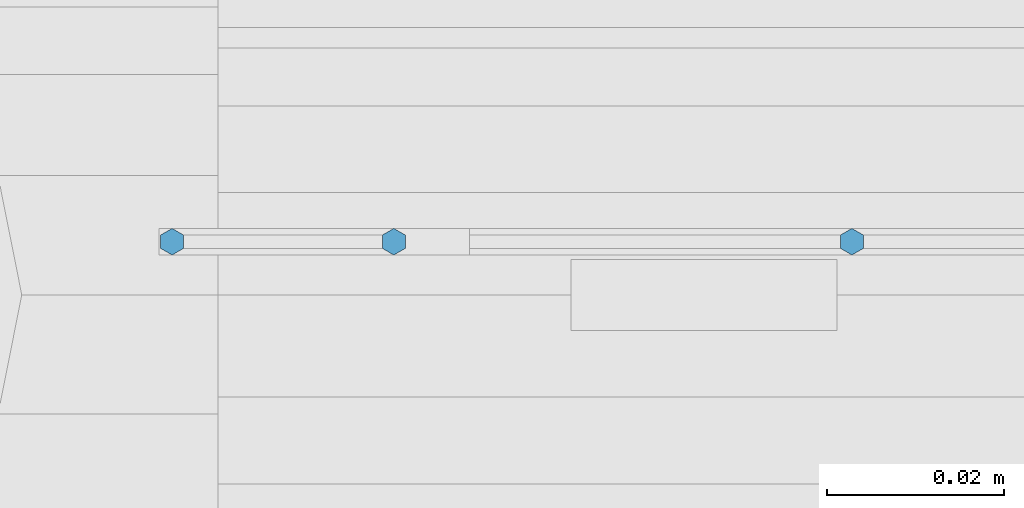
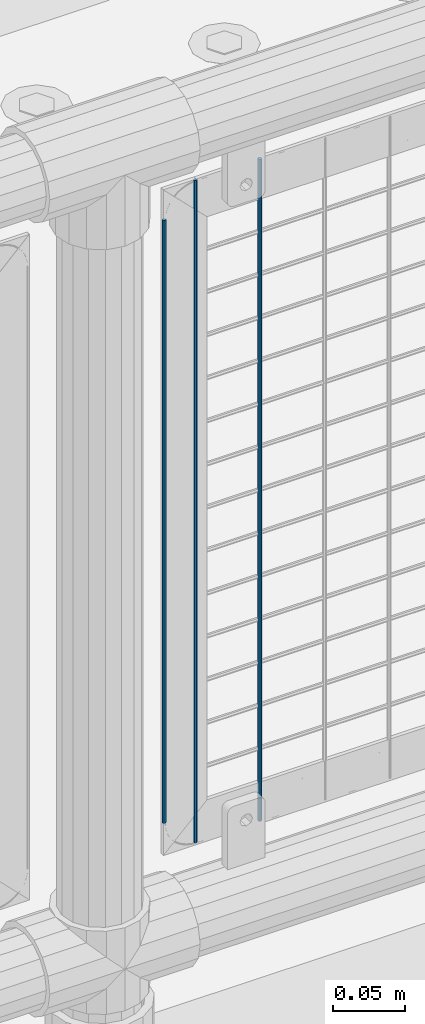
# One storey, part 73 of 219: 3 columns.
"""IFC2X3 building model written with IfcOpenShell, lengths in millimetres."""

import ifcopenshell
import ifcopenshell.guid

model = None  # the IFC model being written
_history = None  # IfcOwnerHistory: only IFC2X3 demands one
_inside = {}  # id of a spatial element -> (the spatial element, [elements in it])
_under = {}  # id of a project, library or spatial element -> (it, [spatial elements below it])
_declared = {}  # id of a project -> (the project, [libraries it declares])
_typed = {}  # id of a type object -> (the type object, [elements of that type])
_made_of = {}  # id of a material, layer set ... -> (it, [elements and type objects made of it])


def new_model(schema):
    """Start an empty IFC model of exactly this schema.

    Asked for "IFC4X3", IfcOpenShell would pick the latest addendum, in which some entities
    have other attributes; the version numbers below select the first issue.
    IFC2X3 requires an IfcOwnerHistory on every rooted entity: one is made here for all.
    """
    global model, _history
    if schema == "IFC4X3":
        model = ifcopenshell.file(schema_version=(4, 3, 0, 0))
    else:
        model = ifcopenshell.file(schema=schema)
    _inside.clear()
    _under.clear()
    _declared.clear()
    _typed.clear()
    _made_of.clear()
    _history = None
    if model.schema == "IFC2X3":
        org = make("IfcOrganization", Name="unknown")
        user = make(
            "IfcPersonAndOrganization",
            ThePerson=make("IfcPerson", FamilyName="unknown"),
            TheOrganization=org,
        )
        app = make(
            "IfcApplication",
            ApplicationDeveloper=org,
            Version="unknown",
            ApplicationFullName="unknown",
            ApplicationIdentifier="unknown",
        )
        _history = make(
            "IfcOwnerHistory",
            OwningUser=user,
            OwningApplication=app,
            ChangeAction="ADDED",
            CreationDate=0,
        )
    return model


def make(cls, **values):
    """One entity of the class cls with the attributes given. An attribute that is None is left unset."""
    return model.create_entity(
        cls, **{name: value for name, value in values.items() if value is not None}
    )


def rooted(cls, **values):
    """An entity with a GlobalId (a new one), such as an element, a storey or a relation."""
    return make(cls, GlobalId=ifcopenshell.guid.new(), OwnerHistory=_history, **values)


def si_unit(unit_type, name, prefix=None):
    """IfcSIUnit, for example si_unit("LENGTHUNIT", "METRE", prefix="MILLI")."""
    return make("IfcSIUnit", UnitType=unit_type, Prefix=prefix, Name=name)


def assignment(units):
    """IfcUnitAssignment: the units of a project."""
    return None if units is None else make("IfcUnitAssignment", Units=units)


def point(xyz):
    """IfcCartesianPoint."""
    return None if xyz is None else make("IfcCartesianPoint", Coordinates=xyz)


def direction(xyz):
    """IfcDirection."""
    return None if xyz is None else make("IfcDirection", DirectionRatios=xyz)


def frame(location, z_axis=None, x_axis=None):
    """IfcAxis2Placement3D, a coordinate frame: its origin and axes. An axis left out is left unset."""
    return make(
        "IfcAxis2Placement3D",
        Location=point(location),
        Axis=direction(z_axis),
        RefDirection=direction(x_axis),
    )


def origin_with_axes():
    """The frame at (0, 0, 0) with the z axis (0, 0, 1) and the x axis (1, 0, 0) written out."""
    return frame((0.0, 0.0, 0.0), z_axis=(0.0, 0.0, 1.0), x_axis=(1.0, 0.0, 0.0))


def place(relative_to, where):
    """IfcLocalPlacement: puts the frame where relative to a parent placement (None: the world)."""
    return make(
        "IfcLocalPlacement", PlacementRelTo=relative_to, RelativePlacement=where
    )


def context(
    kind, dimensions, precision=None, world=None, true_north=None, identifier=None
):
    """IfcGeometricRepresentationContext, for example the 3D "Model" context."""
    return make(
        "IfcGeometricRepresentationContext",
        ContextIdentifier=identifier,
        ContextType=kind,
        CoordinateSpaceDimension=dimensions,
        Precision=precision,
        WorldCoordinateSystem=world,
        TrueNorth=true_north,
    )


def subcontext(parent, identifier, kind, view, scale=None):
    """IfcGeometricRepresentationSubContext, for example "Body" below "Model"."""
    return make(
        "IfcGeometricRepresentationSubContext",
        ContextIdentifier=identifier,
        ContextType=kind,
        ParentContext=parent,
        TargetScale=scale,
        TargetView=view,
    )


def project(units=None, contexts=None):
    """IfcProject with its units and contexts."""
    return rooted(
        "IfcProject",
        Name="project",
        RepresentationContexts=contexts,
        UnitsInContext=assignment(units),
    )


def spatial(cls, under=None, at=None, **own):
    """A site, building, storey or space (cls), placed at a placement, below another one or the project."""
    s = rooted(cls, ObjectPlacement=at, **own)
    if under is not None:
        _under.setdefault(under.id(), (under, []))[1].append(s)
    return s


def faces_of(points, faces, orient=None, outer=None):
    """IfcFace entities. A face is a list of loops; a loop is a list of indices into points, from 0.

    orient and outer hold one flag for each loop. By default every Orientation is true, the
    first loop of a face is its IfcFaceOuterBound and the others are IfcFaceBound.
    """
    made = []
    for i, loops in enumerate(faces):
        bounds = []
        for j, loop in enumerate(loops):
            is_outer = j == 0 if outer is None else outer[i][j]
            bounds.append(
                make(
                    "IfcFaceOuterBound" if is_outer else "IfcFaceBound",
                    Bound=make("IfcPolyLoop", Polygon=[points[k] for k in loop]),
                    Orientation=True if orient is None else orient[i][j],
                )
            )
        made.append(make("IfcFace", Bounds=bounds))
    return made


def faceted_brep(points, faces, orient=None, outer=None, voids=None):
    """IfcFacetedBrep: a solid bounded by flat faces; with voids (closed shells), ...WithVoids."""
    shared = [point(p) for p in points]
    hull = make("IfcClosedShell", CfsFaces=faces_of(shared, faces, orient, outer))
    if voids is None:
        return make("IfcFacetedBrep", Outer=hull)
    return make(
        "IfcFacetedBrepWithVoids",
        Outer=hull,
        Voids=[
            make(cls, CfsFaces=faces_of(shared, fs, o, b)) for cls, fs, o, b in voids
        ],
    )


def shape(context_of_items, identifier, shape_type, items):
    """IfcShapeRepresentation: the items that make up one representation, for example the "Body"."""
    return make(
        "IfcShapeRepresentation",
        ContextOfItems=context_of_items,
        RepresentationIdentifier=identifier,
        RepresentationType=shape_type,
        Items=items,
    )


def material(Name=None, Category=None):
    """IfcMaterial."""
    return make("IfcMaterial", Name=Name, Category=Category)


def made_of(thing, what):
    """Note that an element or type object is made of a material, layer set ...; save() writes the relation."""
    if what is not None:
        _made_of.setdefault(what.id(), (what, []))[1].append(thing)
    return thing


def type_object(cls, material=None, **own):
    """A type object (cls), such as IfcWallType, which elements share."""
    return made_of(rooted(cls, **own), material)


def element(
    cls,
    number,
    at=None,
    inside=None,
    cuts=None,
    type_object=None,
    material=None,
    context=None,
    identifier="Body",
    shape_type=None,
    held_by="IfcProductDefinitionShape",
    body=None,
    shapes=None,
    **own,
):
    """One element of the class cls, such as IfcWall. Its Tag is "e" and its number.

    at: its placement. inside: the storey or other place that contains it. cuts: it is an
    opening in that element (IfcRelVoidsElement). A single representation is given by context,
    identifier, shape_type and body (its items); several are given by shapes. held_by: the class
    of the entity that holds the representations. save() writes the other relations.
    """
    e = rooted(cls, Tag="e%d" % number, ObjectPlacement=at, **own)
    if body is not None:
        shapes = [shape(context, identifier, shape_type, body)]
    if shapes is not None:
        e.Representation = make(held_by, Representations=shapes)
    if inside is not None:
        _inside.setdefault(inside.id(), (inside, []))[1].append(e)
    if cuts is not None:
        rooted(
            "IfcRelVoidsElement", RelatingBuildingElement=cuts, RelatedOpeningElement=e
        )
    if type_object is not None:
        _typed.setdefault(type_object.id(), (type_object, []))[1].append(e)
    return made_of(e, material)


def aggregate(whole, parts):
    """IfcRelAggregates: a whole, such as a stair, and the parts it consists of."""
    return rooted("IfcRelAggregates", RelatingObject=whole, RelatedObjects=parts)


def save(model, path):
    """Write the relations noted so far, then the file.

    IfcRelAggregates (storeys below a building ...), IfcRelContainedInSpatialStructure (elements
    in a storey), IfcRelDefinesByType, IfcRelAssociatesMaterial and IfcRelDeclares: one each for
    every whole, place, type object, material and project.
    """
    for whole, parts in _under.values():
        aggregate(whole, parts)
    for where, things in _inside.values():
        rooted(
            "IfcRelContainedInSpatialStructure",
            RelatedElements=things,
            RelatingStructure=where,
        )
    for kind, things in _typed.values():
        rooted("IfcRelDefinesByType", RelatedObjects=things, RelatingType=kind)
    for what, things in _made_of.values():
        rooted("IfcRelAssociatesMaterial", RelatedObjects=things, RelatingMaterial=what)
    for by, libraries in _declared.values():
        rooted("IfcRelDeclares", RelatingContext=by, RelatedDefinitions=libraries)
    model.write(path)


model = new_model("IFC2X3")

# Units and contexts
model_context = context("Model", 3, precision=1e-05, world=origin_with_axes())
body_context = subcontext(model_context, "Body", "Model", "MODEL_VIEW")
ifc_project = project(units=[si_unit("LENGTHUNIT", "METRE", prefix="MILLI"), si_unit("AREAUNIT", "SQUARE_METRE"), si_unit("VOLUMEUNIT", "CUBIC_METRE"), si_unit("MASSUNIT", "GRAM", prefix="KILO"), si_unit("TIMEUNIT", "SECOND"), si_unit("PLANEANGLEUNIT", "RADIAN"), si_unit("SOLIDANGLEUNIT", "STERADIAN"), si_unit("THERMODYNAMICTEMPERATUREUNIT", "DEGREE_CELSIUS"), si_unit("LUMINOUSINTENSITYUNIT", "LUMEN")], contexts=[model_context])

# Site, building, storey
site_placement = place(None, origin_with_axes())
site = spatial("IfcSite", under=ifc_project, at=site_placement, CompositionType="ELEMENT")
building_placement = place(site_placement, origin_with_axes())
building = spatial("IfcBuilding", under=site, at=building_placement, Name="Standard", CompositionType="ELEMENT")
storey_placement = place(building_placement, origin_with_axes())
storey = spatial("IfcBuildingStorey", under=building, at=storey_placement, Name="Undefined", CompositionType="ELEMENT", Elevation=0.0)

# Columns
ifc_material = material(Name="Misc_Undefined")
column_type = type_object("IfcColumnType", Name="D3", PredefinedType="NOTDEFINED")
column_1_placement = place(storey_placement, frame((4068.655, 31670.5, 353.02), z_axis=(-1.0, 0.0, 0.0), x_axis=(0.0, 0.0, 1.0)))
element("IfcColumn", 1, at=column_1_placement, inside=storey, type_object=column_type, material=ifc_material, ObjectType="D3", context=body_context, shape_type="Brep", body=[
    faceted_brep([(0.0, -1.5, -5.6843418860808e-14), (0.0, -0.75, -1.29903810567669), (560.0, -0.75, -1.29903810567703), (560.0, -1.5, 0.0), (0.0, 0.75, -1.29903810567669), (560.0, 0.75, -1.29903810567703), (0.0, 1.5, -5.6843418860808e-14), (560.0, 1.5, 0.0), (0.0, 0.75, 1.29903810567669), (560.0, 0.75, 1.29903810567703), (0.0, -0.75, 1.29903810567669), (560.0, -0.75, 1.29903810567703)], [[[0, 1, 2, 3]], [[1, 4, 5, 2]], [[4, 6, 7, 5]], [[6, 8, 9, 7]], [[8, 10, 11, 9]], [[10, 0, 3, 11]], [[5, 7, 9, 11, 3, 2]], [[10, 8, 6, 4, 1, 0]]]),
])
column_2_placement = place(storey_placement, frame((3992.0, 31670.5, 378.02), z_axis=(-1.0, 0.0, 0.0), x_axis=(0.0, 0.0, 1.0)))
element("IfcColumn", 2, at=column_2_placement, inside=storey, type_object=column_type, material=ifc_material, ObjectType="D3", context=body_context, shape_type="Brep", body=[
    faceted_brep([(0.0, -1.5, -5.6843418860808e-14), (0.0, -0.75, -1.29903810567669), (510.0, -0.75, -1.29903810567703), (510.0, -1.5, 0.0), (0.0, 0.75, -1.29903810567669), (510.0, 0.75, -1.29903810567703), (0.0, 1.5, -5.6843418860808e-14), (510.0, 1.5, 0.0), (0.0, 0.75, 1.29903810567669), (510.0, 0.75, 1.29903810567703), (0.0, -0.75, 1.29903810567669), (510.0, -0.75, 1.29903810567703)], [[[0, 1, 2, 3]], [[1, 4, 5, 2]], [[4, 6, 7, 5]], [[6, 8, 9, 7]], [[8, 10, 11, 9]], [[10, 0, 3, 11]], [[5, 7, 9, 11, 3, 2]], [[10, 8, 6, 4, 1, 0]]]),
])
column_3_placement = place(storey_placement, frame((4017.0, 31670.5, 353.02), z_axis=(-1.0, 0.0, 0.0), x_axis=(0.0, 0.0, 1.0)))
element("IfcColumn", 3, at=column_3_placement, inside=storey, type_object=column_type, material=ifc_material, ObjectType="D3", context=body_context, shape_type="Brep", body=[
    faceted_brep([(0.0, -1.5, -5.6843418860808e-14), (0.0, -0.75, -1.29903810567669), (560.0, -0.75, -1.29903810567703), (560.0, -1.5, 0.0), (0.0, 0.75, -1.29903810567669), (560.0, 0.75, -1.29903810567703), (0.0, 1.5, -5.6843418860808e-14), (560.0, 1.5, 0.0), (0.0, 0.75, 1.29903810567669), (560.0, 0.75, 1.29903810567703), (0.0, -0.75, 1.29903810567669), (560.0, -0.75, 1.29903810567703)], [[[0, 1, 2, 3]], [[1, 4, 5, 2]], [[4, 6, 7, 5]], [[6, 8, 9, 7]], [[8, 10, 11, 9]], [[10, 0, 3, 11]], [[5, 7, 9, 11, 3, 2]], [[10, 8, 6, 4, 1, 0]]]),
])

save(model, "model.ifc")
